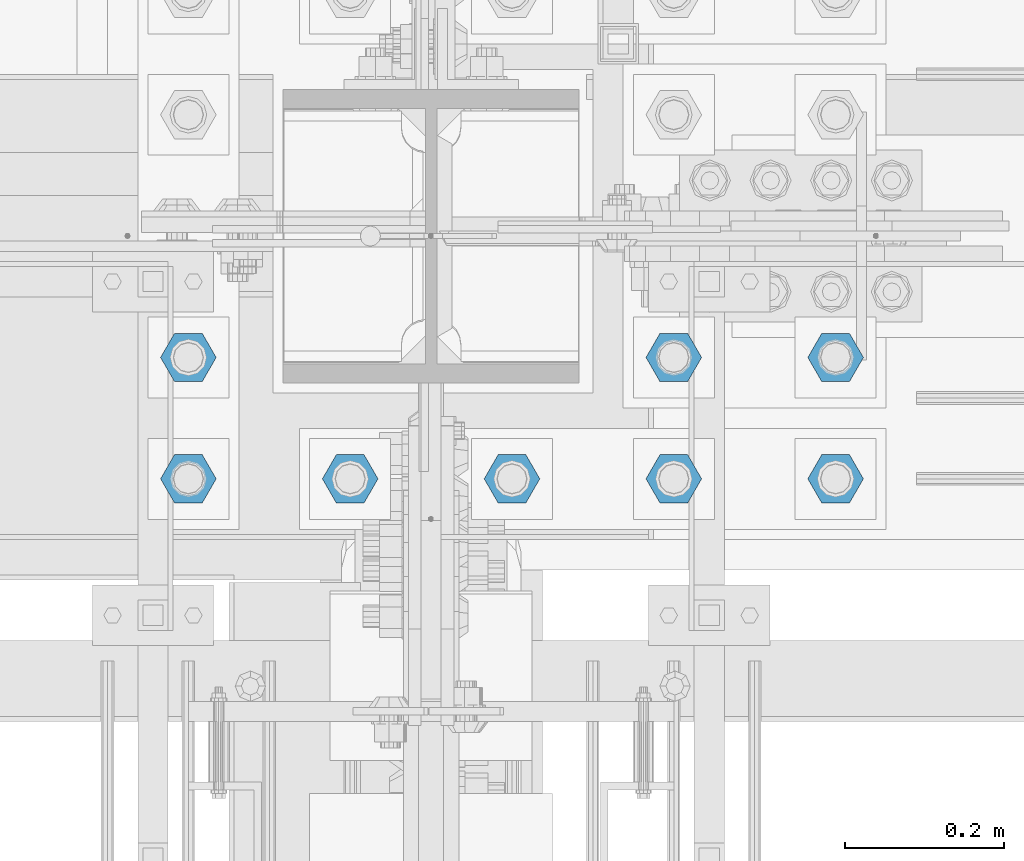
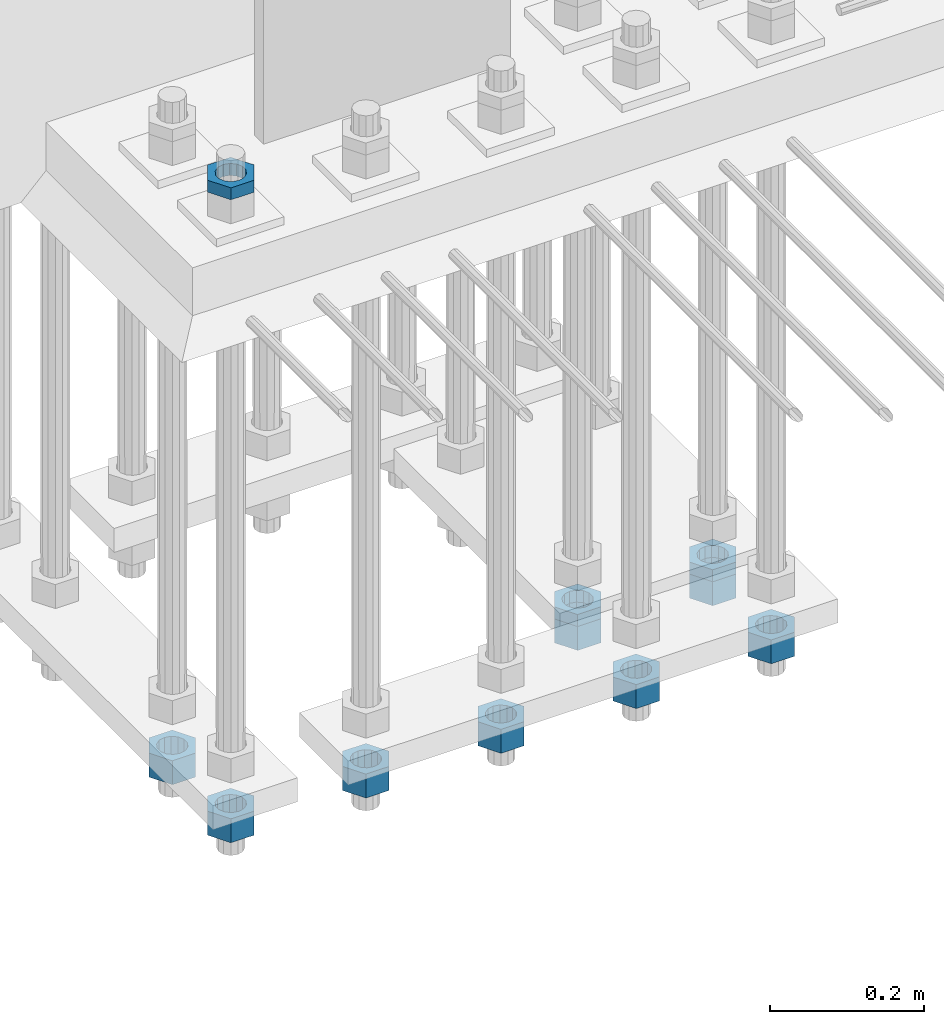
# One storey, part 2824 of 3843: 11 beams, 1 element without a shape of its own.
"""IFC2X3 building model written with IfcOpenShell, lengths in millimetres."""

import ifcopenshell
import ifcopenshell.guid

model = None  # the IFC model being written
_history = None  # IfcOwnerHistory: only IFC2X3 demands one
_inside = {}  # id of a spatial element -> (the spatial element, [elements in it])
_under = {}  # id of a project, library or spatial element -> (it, [spatial elements below it])
_declared = {}  # id of a project -> (the project, [libraries it declares])
_typed = {}  # id of a type object -> (the type object, [elements of that type])
_made_of = {}  # id of a material, layer set ... -> (it, [elements and type objects made of it])


def new_model(schema):
    """Start an empty IFC model of exactly this schema.

    Asked for "IFC4X3", IfcOpenShell would pick the latest addendum, in which some entities
    have other attributes; the version numbers below select the first issue.
    IFC2X3 requires an IfcOwnerHistory on every rooted entity: one is made here for all.
    """
    global model, _history
    if schema == "IFC4X3":
        model = ifcopenshell.file(schema_version=(4, 3, 0, 0))
    else:
        model = ifcopenshell.file(schema=schema)
    _inside.clear()
    _under.clear()
    _declared.clear()
    _typed.clear()
    _made_of.clear()
    _history = None
    if model.schema == "IFC2X3":
        org = make("IfcOrganization", Name="unknown")
        user = make(
            "IfcPersonAndOrganization",
            ThePerson=make("IfcPerson", FamilyName="unknown"),
            TheOrganization=org,
        )
        app = make(
            "IfcApplication",
            ApplicationDeveloper=org,
            Version="unknown",
            ApplicationFullName="unknown",
            ApplicationIdentifier="unknown",
        )
        _history = make(
            "IfcOwnerHistory",
            OwningUser=user,
            OwningApplication=app,
            ChangeAction="ADDED",
            CreationDate=0,
        )
    return model


def make(cls, **values):
    """One entity of the class cls with the attributes given. An attribute that is None is left unset."""
    return model.create_entity(
        cls, **{name: value for name, value in values.items() if value is not None}
    )


def rooted(cls, **values):
    """An entity with a GlobalId (a new one), such as an element, a storey or a relation."""
    return make(cls, GlobalId=ifcopenshell.guid.new(), OwnerHistory=_history, **values)


def si_unit(unit_type, name, prefix=None):
    """IfcSIUnit, for example si_unit("LENGTHUNIT", "METRE", prefix="MILLI")."""
    return make("IfcSIUnit", UnitType=unit_type, Prefix=prefix, Name=name)


def assignment(units):
    """IfcUnitAssignment: the units of a project."""
    return None if units is None else make("IfcUnitAssignment", Units=units)


def point(xyz):
    """IfcCartesianPoint."""
    return None if xyz is None else make("IfcCartesianPoint", Coordinates=xyz)


def direction(xyz):
    """IfcDirection."""
    return None if xyz is None else make("IfcDirection", DirectionRatios=xyz)


def frame(location, z_axis=None, x_axis=None):
    """IfcAxis2Placement3D, a coordinate frame: its origin and axes. An axis left out is left unset."""
    return make(
        "IfcAxis2Placement3D",
        Location=point(location),
        Axis=direction(z_axis),
        RefDirection=direction(x_axis),
    )


def origin_with_axes():
    """The frame at (0, 0, 0) with the z axis (0, 0, 1) and the x axis (1, 0, 0) written out."""
    return frame((0.0, 0.0, 0.0), z_axis=(0.0, 0.0, 1.0), x_axis=(1.0, 0.0, 0.0))


def place(relative_to, where):
    """IfcLocalPlacement: puts the frame where relative to a parent placement (None: the world)."""
    return make(
        "IfcLocalPlacement", PlacementRelTo=relative_to, RelativePlacement=where
    )


def context(
    kind, dimensions, precision=None, world=None, true_north=None, identifier=None
):
    """IfcGeometricRepresentationContext, for example the 3D "Model" context."""
    return make(
        "IfcGeometricRepresentationContext",
        ContextIdentifier=identifier,
        ContextType=kind,
        CoordinateSpaceDimension=dimensions,
        Precision=precision,
        WorldCoordinateSystem=world,
        TrueNorth=true_north,
    )


def subcontext(parent, identifier, kind, view, scale=None):
    """IfcGeometricRepresentationSubContext, for example "Body" below "Model"."""
    return make(
        "IfcGeometricRepresentationSubContext",
        ContextIdentifier=identifier,
        ContextType=kind,
        ParentContext=parent,
        TargetScale=scale,
        TargetView=view,
    )


def project(units=None, contexts=None):
    """IfcProject with its units and contexts."""
    return rooted(
        "IfcProject",
        Name="project",
        RepresentationContexts=contexts,
        UnitsInContext=assignment(units),
    )


def spatial(cls, under=None, at=None, **own):
    """A site, building, storey or space (cls), placed at a placement, below another one or the project."""
    s = rooted(cls, ObjectPlacement=at, **own)
    if under is not None:
        _under.setdefault(under.id(), (under, []))[1].append(s)
    return s


def faces_of(points, faces, orient=None, outer=None):
    """IfcFace entities. A face is a list of loops; a loop is a list of indices into points, from 0.

    orient and outer hold one flag for each loop. By default every Orientation is true, the
    first loop of a face is its IfcFaceOuterBound and the others are IfcFaceBound.
    """
    made = []
    for i, loops in enumerate(faces):
        bounds = []
        for j, loop in enumerate(loops):
            is_outer = j == 0 if outer is None else outer[i][j]
            bounds.append(
                make(
                    "IfcFaceOuterBound" if is_outer else "IfcFaceBound",
                    Bound=make("IfcPolyLoop", Polygon=[points[k] for k in loop]),
                    Orientation=True if orient is None else orient[i][j],
                )
            )
        made.append(make("IfcFace", Bounds=bounds))
    return made


def faceted_brep(points, faces, orient=None, outer=None, voids=None):
    """IfcFacetedBrep: a solid bounded by flat faces; with voids (closed shells), ...WithVoids."""
    shared = [point(p) for p in points]
    hull = make("IfcClosedShell", CfsFaces=faces_of(shared, faces, orient, outer))
    if voids is None:
        return make("IfcFacetedBrep", Outer=hull)
    return make(
        "IfcFacetedBrepWithVoids",
        Outer=hull,
        Voids=[
            make(cls, CfsFaces=faces_of(shared, fs, o, b)) for cls, fs, o, b in voids
        ],
    )


def shape(context_of_items, identifier, shape_type, items):
    """IfcShapeRepresentation: the items that make up one representation, for example the "Body"."""
    return make(
        "IfcShapeRepresentation",
        ContextOfItems=context_of_items,
        RepresentationIdentifier=identifier,
        RepresentationType=shape_type,
        Items=items,
    )


def material(Name=None, Category=None):
    """IfcMaterial."""
    return make("IfcMaterial", Name=Name, Category=Category)


def made_of(thing, what):
    """Note that an element or type object is made of a material, layer set ...; save() writes the relation."""
    if what is not None:
        _made_of.setdefault(what.id(), (what, []))[1].append(thing)
    return thing


def type_object(cls, material=None, **own):
    """A type object (cls), such as IfcWallType, which elements share."""
    return made_of(rooted(cls, **own), material)


def element(
    cls,
    number,
    at=None,
    inside=None,
    cuts=None,
    type_object=None,
    material=None,
    context=None,
    identifier="Body",
    shape_type=None,
    held_by="IfcProductDefinitionShape",
    body=None,
    shapes=None,
    **own,
):
    """One element of the class cls, such as IfcWall. Its Tag is "e" and its number.

    at: its placement. inside: the storey or other place that contains it. cuts: it is an
    opening in that element (IfcRelVoidsElement). A single representation is given by context,
    identifier, shape_type and body (its items); several are given by shapes. held_by: the class
    of the entity that holds the representations. save() writes the other relations.
    """
    e = rooted(cls, Tag="e%d" % number, ObjectPlacement=at, **own)
    if body is not None:
        shapes = [shape(context, identifier, shape_type, body)]
    if shapes is not None:
        e.Representation = make(held_by, Representations=shapes)
    if inside is not None:
        _inside.setdefault(inside.id(), (inside, []))[1].append(e)
    if cuts is not None:
        rooted(
            "IfcRelVoidsElement", RelatingBuildingElement=cuts, RelatedOpeningElement=e
        )
    if type_object is not None:
        _typed.setdefault(type_object.id(), (type_object, []))[1].append(e)
    return made_of(e, material)


def aggregate(whole, parts):
    """IfcRelAggregates: a whole, such as a stair, and the parts it consists of."""
    return rooted("IfcRelAggregates", RelatingObject=whole, RelatedObjects=parts)


def save(model, path):
    """Write the relations noted so far, then the file.

    IfcRelAggregates (storeys below a building ...), IfcRelContainedInSpatialStructure (elements
    in a storey), IfcRelDefinesByType, IfcRelAssociatesMaterial and IfcRelDeclares: one each for
    every whole, place, type object, material and project.
    """
    for whole, parts in _under.values():
        aggregate(whole, parts)
    for where, things in _inside.values():
        rooted(
            "IfcRelContainedInSpatialStructure",
            RelatedElements=things,
            RelatingStructure=where,
        )
    for kind, things in _typed.values():
        rooted("IfcRelDefinesByType", RelatedObjects=things, RelatingType=kind)
    for what, things in _made_of.values():
        rooted("IfcRelAssociatesMaterial", RelatedObjects=things, RelatingMaterial=what)
    for by, libraries in _declared.values():
        rooted("IfcRelDeclares", RelatingContext=by, RelatedDefinitions=libraries)
    model.write(path)


model = new_model("IFC2X3")

# Units and contexts
model_context = context("Model", 3, precision=1e-05, world=origin_with_axes())
body_context = subcontext(model_context, "Body", "Model", "MODEL_VIEW")
ifc_project = project(units=[si_unit("LENGTHUNIT", "METRE", prefix="MILLI"), si_unit("AREAUNIT", "SQUARE_METRE"), si_unit("VOLUMEUNIT", "CUBIC_METRE"), si_unit("MASSUNIT", "GRAM", prefix="KILO"), si_unit("TIMEUNIT", "SECOND"), si_unit("PLANEANGLEUNIT", "RADIAN"), si_unit("SOLIDANGLEUNIT", "STERADIAN"), si_unit("THERMODYNAMICTEMPERATUREUNIT", "DEGREE_CELSIUS"), si_unit("LUMINOUSINTENSITYUNIT", "LUMEN")], contexts=[model_context])

# Site, building, storey
site_placement = place(None, origin_with_axes())
site = spatial("IfcSite", under=ifc_project, at=site_placement, CompositionType="ELEMENT")
building_placement = place(site_placement, origin_with_axes())
building = spatial("IfcBuilding", under=site, at=building_placement, Name="Undefined", CompositionType="ELEMENT")
storey_placement = place(building_placement, origin_with_axes())
storey = spatial("IfcBuildingStorey", under=building, at=storey_placement, Name="Undefined", CompositionType="ELEMENT", Elevation=0.0)

# Assembly, beams
assembly_placement = place(storey_placement, origin_with_axes())
assembly = element("IfcElementAssembly", 1, at=assembly_placement, inside=storey, Name="TEMPLATE", AssemblyPlace="NOTDEFINED", PredefinedType="RIGID_FRAME")
ifc_material = material(Name="STEEL/A572-50")
beam_type_1 = type_object("IfcBeamType", Name="1-1/2_HEAVY_HEX_NUT", PredefinedType="NOTDEFINED")
beam_1_placement = place(assembly_placement, frame((55626.0, 25311.1, 28746.4500015259), z_axis=(0.0, -1.0, 0.0), x_axis=(0.0, 0.0, -1.0)))
beam_1 = element("IfcBeam", 2, at=beam_1_placement, type_object=beam_type_1, material=ifc_material, Name="NUT", ObjectType="1-1/2_HEAVY_HEX_NUT", context=body_context, shape_type="Brep", body=[
    faceted_brep([(0.0, -34.9199981689453, 0.0), (0.0, -17.4599990844727, -30.25), (38.0999999999985, -17.4599990844727, -30.25), (38.0999999999985, -34.9199981689453, 0.0), (0.0, 17.4599990844727, -30.25), (38.0999999999985, 17.4599990844727, -30.25), (0.0, 34.9199981689453, 0.0), (38.0999999999985, 34.9199981689453, 0.0), (0.0, 17.4599990844727, 30.25), (38.0999999999985, 17.4599990844727, 30.25), (0.0, -17.4599990844727, 30.25), (38.0999999999985, -17.4599990844727, 30.25), (0.0, 0.0, 20.6399993896484), (0.0, 8.9553601105581, 18.5959968835959), (38.0999999999985, 8.9553601105581, 18.5959968835959), (38.0999999999985, 0.0, 20.6399993896484), (0.0, 16.1370013209525, 12.8688291298167), (38.0999999999985, 16.1370013209525, 12.8688291298167), (0.0, 20.1225115123816, 4.59283194104501), (38.0999999999985, 20.1225115123816, 4.59283194104501), (0.0, 20.1225115123816, -4.59283194104501), (38.0999999999985, 20.1225115123816, -4.59283194104501), (0.0, 16.1370013209525, -12.8688291298167), (38.0999999999985, 16.1370013209525, -12.8688291298167), (0.0, 8.9553601105581, -18.5959968835959), (38.0999999999985, 8.9553601105581, -18.5959968835959), (0.0, 0.0, -20.6399993896484), (38.0999999999985, 0.0, -20.6399993896484), (0.0, -8.9553601105581, -18.5959968835959), (38.0999999999985, -8.9553601105581, -18.5959968835959), (0.0, -16.1370013209525, -12.8688291298167), (38.0999999999985, -16.1370013209525, -12.8688291298167), (0.0, -20.1225115123816, -4.59283194104501), (38.0999999999985, -20.1225115123816, -4.59283194104501), (0.0, -20.1225115123816, 4.59283194104501), (38.0999999999985, -20.1225115123816, 4.59283194104501), (0.0, -16.1370013209525, 12.8688291298167), (38.0999999999985, -16.1370013209525, 12.8688291298167), (0.0, -8.9553601105581, 18.5959968835959), (38.0999999999985, -8.9553601105581, 18.5959968835959)], [[[0, 1, 2, 3]], [[1, 4, 5, 2]], [[4, 6, 7, 5]], [[6, 8, 9, 7]], [[8, 10, 11, 9]], [[10, 0, 3, 11]], [[12, 13, 14, 15]], [[13, 16, 17, 14]], [[16, 18, 19, 17]], [[18, 20, 21, 19]], [[20, 22, 23, 21]], [[22, 24, 25, 23]], [[24, 26, 27, 25]], [[26, 28, 29, 27]], [[28, 30, 31, 29]], [[30, 32, 33, 31]], [[32, 34, 35, 33]], [[34, 36, 37, 35]], [[36, 38, 39, 37]], [[38, 12, 15, 39]], [[5, 7, 9, 11, 3, 2], [17, 19, 21, 23, 25, 27, 29, 31, 33, 35, 37, 39, 15, 14]], [[10, 8, 6, 4, 1, 0], [38, 36, 34, 32, 30, 28, 26, 24, 22, 20, 18, 16, 13, 12]]]),
])
beam_2_placement = place(assembly_placement, frame((55829.2, 25311.1, 28746.4500015259), z_axis=(0.0, -1.0, 0.0), x_axis=(0.0, 0.0, -1.0)))
beam_2 = element("IfcBeam", 3, at=beam_2_placement, type_object=beam_type_1, material=ifc_material, Name="NUT", ObjectType="1-1/2_HEAVY_HEX_NUT", context=body_context, shape_type="Brep", body=[
    faceted_brep([(0.0, -34.9199981689453, 0.0), (0.0, -17.4599990844727, -30.25), (38.0999999999985, -17.4599990844727, -30.25), (38.0999999999985, -34.9199981689453, 0.0), (0.0, 17.4599990844727, -30.25), (38.0999999999985, 17.4599990844727, -30.25), (0.0, 34.9199981689453, 0.0), (38.0999999999985, 34.9199981689453, 0.0), (0.0, 17.4599990844727, 30.25), (38.0999999999985, 17.4599990844727, 30.25), (0.0, -17.4599990844727, 30.25), (38.0999999999985, -17.4599990844727, 30.25), (0.0, 0.0, 20.6399993896484), (0.0, 8.9553601105581, 18.5959968835959), (38.0999999999985, 8.9553601105581, 18.5959968835959), (38.0999999999985, 0.0, 20.6399993896484), (0.0, 16.1370013209525, 12.8688291298167), (38.0999999999985, 16.1370013209525, 12.8688291298167), (0.0, 20.1225115123816, 4.59283194104501), (38.0999999999985, 20.1225115123816, 4.59283194104501), (0.0, 20.1225115123816, -4.59283194104501), (38.0999999999985, 20.1225115123816, -4.59283194104501), (0.0, 16.1370013209525, -12.8688291298167), (38.0999999999985, 16.1370013209525, -12.8688291298167), (0.0, 8.9553601105581, -18.5959968835959), (38.0999999999985, 8.9553601105581, -18.5959968835959), (0.0, 0.0, -20.6399993896484), (38.0999999999985, 0.0, -20.6399993896484), (0.0, -8.9553601105581, -18.5959968835959), (38.0999999999985, -8.9553601105581, -18.5959968835959), (0.0, -16.1370013209525, -12.8688291298167), (38.0999999999985, -16.1370013209525, -12.8688291298167), (0.0, -20.1225115123816, -4.59283194104501), (38.0999999999985, -20.1225115123816, -4.59283194104501), (0.0, -20.1225115123816, 4.59283194104501), (38.0999999999985, -20.1225115123816, 4.59283194104501), (0.0, -16.1370013209525, 12.8688291298167), (38.0999999999985, -16.1370013209525, 12.8688291298167), (0.0, -8.9553601105581, 18.5959968835959), (38.0999999999985, -8.9553601105581, 18.5959968835959)], [[[0, 1, 2, 3]], [[1, 4, 5, 2]], [[4, 6, 7, 5]], [[6, 8, 9, 7]], [[8, 10, 11, 9]], [[10, 0, 3, 11]], [[12, 13, 14, 15]], [[13, 16, 17, 14]], [[16, 18, 19, 17]], [[18, 20, 21, 19]], [[20, 22, 23, 21]], [[22, 24, 25, 23]], [[24, 26, 27, 25]], [[26, 28, 29, 27]], [[28, 30, 31, 29]], [[30, 32, 33, 31]], [[32, 34, 35, 33]], [[34, 36, 37, 35]], [[36, 38, 39, 37]], [[38, 12, 15, 39]], [[5, 7, 9, 11, 3, 2], [17, 19, 21, 23, 25, 27, 29, 31, 33, 35, 37, 39, 15, 14]], [[10, 8, 6, 4, 1, 0], [38, 36, 34, 32, 30, 28, 26, 24, 22, 20, 18, 16, 13, 12]]]),
])
beam_3_placement = place(assembly_placement, frame((56032.4, 25311.1, 28746.4500015259), z_axis=(0.0, -1.0, 0.0), x_axis=(0.0, 0.0, -1.0)))
beam_3 = element("IfcBeam", 4, at=beam_3_placement, type_object=beam_type_1, material=ifc_material, Name="NUT", ObjectType="1-1/2_HEAVY_HEX_NUT", context=body_context, shape_type="Brep", body=[
    faceted_brep([(0.0, -34.9199981689453, 0.0), (0.0, -17.4599990844727, -30.25), (38.0999999999985, -17.4599990844727, -30.25), (38.0999999999985, -34.9199981689453, 0.0), (0.0, 17.4599990844727, -30.25), (38.0999999999985, 17.4599990844727, -30.25), (0.0, 34.9199981689453, 0.0), (38.0999999999985, 34.9199981689453, 0.0), (0.0, 17.4599990844727, 30.25), (38.0999999999985, 17.4599990844727, 30.25), (0.0, -17.4599990844727, 30.25), (38.0999999999985, -17.4599990844727, 30.25), (0.0, 0.0, 20.6399993896484), (0.0, 8.9553601105581, 18.5959968835959), (38.0999999999985, 8.9553601105581, 18.5959968835959), (38.0999999999985, 0.0, 20.6399993896484), (0.0, 16.1370013209525, 12.8688291298167), (38.0999999999985, 16.1370013209525, 12.8688291298167), (0.0, 20.1225115123816, 4.59283194104501), (38.0999999999985, 20.1225115123816, 4.59283194104501), (0.0, 20.1225115123816, -4.59283194104501), (38.0999999999985, 20.1225115123816, -4.59283194104501), (0.0, 16.1370013209525, -12.8688291298167), (38.0999999999985, 16.1370013209525, -12.8688291298167), (0.0, 8.9553601105581, -18.5959968835959), (38.0999999999985, 8.9553601105581, -18.5959968835959), (0.0, 0.0, -20.6399993896484), (38.0999999999985, 0.0, -20.6399993896484), (0.0, -8.9553601105581, -18.5959968835959), (38.0999999999985, -8.9553601105581, -18.5959968835959), (0.0, -16.1370013209525, -12.8688291298167), (38.0999999999985, -16.1370013209525, -12.8688291298167), (0.0, -20.1225115123816, -4.59283194104501), (38.0999999999985, -20.1225115123816, -4.59283194104501), (0.0, -20.1225115123816, 4.59283194104501), (38.0999999999985, -20.1225115123816, 4.59283194104501), (0.0, -16.1370013209525, 12.8688291298167), (38.0999999999985, -16.1370013209525, 12.8688291298167), (0.0, -8.9553601105581, 18.5959968835959), (38.0999999999985, -8.9553601105581, 18.5959968835959)], [[[0, 1, 2, 3]], [[1, 4, 5, 2]], [[4, 6, 7, 5]], [[6, 8, 9, 7]], [[8, 10, 11, 9]], [[10, 0, 3, 11]], [[12, 13, 14, 15]], [[13, 16, 17, 14]], [[16, 18, 19, 17]], [[18, 20, 21, 19]], [[20, 22, 23, 21]], [[22, 24, 25, 23]], [[24, 26, 27, 25]], [[26, 28, 29, 27]], [[28, 30, 31, 29]], [[30, 32, 33, 31]], [[32, 34, 35, 33]], [[34, 36, 37, 35]], [[36, 38, 39, 37]], [[38, 12, 15, 39]], [[5, 7, 9, 11, 3, 2], [17, 19, 21, 23, 25, 27, 29, 31, 33, 35, 37, 39, 15, 14]], [[10, 8, 6, 4, 1, 0], [38, 36, 34, 32, 30, 28, 26, 24, 22, 20, 18, 16, 13, 12]]]),
])
beam_4_placement = place(assembly_placement, frame((56235.6, 25311.1, 28746.4500015259), z_axis=(0.0, 1.0, 0.0), x_axis=(0.0, 0.0, -1.0)))
beam_4 = element("IfcBeam", 5, at=beam_4_placement, type_object=beam_type_1, material=ifc_material, Name="NUT", ObjectType="1-1/2_HEAVY_HEX_NUT", context=body_context, shape_type="Brep", body=[
    faceted_brep([(0.0, -34.9199981689453, 0.0), (0.0, -17.4599990844727, -30.25), (38.0999999999985, -17.4599990844727, -30.25), (38.0999999999985, -34.9199981689453, 0.0), (0.0, 17.4599990844727, -30.25), (38.0999999999985, 17.4599990844727, -30.25), (0.0, 34.9199981689453, 0.0), (38.0999999999985, 34.9199981689453, 0.0), (0.0, 17.4599990844727, 30.25), (38.0999999999985, 17.4599990844727, 30.25), (0.0, -17.4599990844727, 30.25), (38.0999999999985, -17.4599990844727, 30.25), (0.0, 0.0, 20.6399993896484), (0.0, 8.9553601105581, 18.5959968835959), (38.0999999999985, 8.9553601105581, 18.5959968835959), (38.0999999999985, 0.0, 20.6399993896484), (0.0, 16.1370013209525, 12.8688291298167), (38.0999999999985, 16.1370013209525, 12.8688291298167), (0.0, 20.1225115123816, 4.59283194104501), (38.0999999999985, 20.1225115123816, 4.59283194104501), (0.0, 20.1225115123816, -4.59283194104501), (38.0999999999985, 20.1225115123816, -4.59283194104501), (0.0, 16.1370013209525, -12.8688291298167), (38.0999999999985, 16.1370013209525, -12.8688291298167), (0.0, 8.9553601105581, -18.5959968835959), (38.0999999999985, 8.9553601105581, -18.5959968835959), (0.0, 0.0, -20.6399993896484), (38.0999999999985, 0.0, -20.6399993896484), (0.0, -8.9553601105581, -18.5959968835959), (38.0999999999985, -8.9553601105581, -18.5959968835959), (0.0, -16.1370013209525, -12.8688291298167), (38.0999999999985, -16.1370013209525, -12.8688291298167), (0.0, -20.1225115123816, -4.59283194104501), (38.0999999999985, -20.1225115123816, -4.59283194104501), (0.0, -20.1225115123816, 4.59283194104501), (38.0999999999985, -20.1225115123816, 4.59283194104501), (0.0, -16.1370013209525, 12.8688291298167), (38.0999999999985, -16.1370013209525, 12.8688291298167), (0.0, -8.9553601105581, 18.5959968835959), (38.0999999999985, -8.9553601105581, 18.5959968835959)], [[[0, 1, 2, 3]], [[1, 4, 5, 2]], [[4, 6, 7, 5]], [[6, 8, 9, 7]], [[8, 10, 11, 9]], [[10, 0, 3, 11]], [[12, 13, 14, 15]], [[13, 16, 17, 14]], [[16, 18, 19, 17]], [[18, 20, 21, 19]], [[20, 22, 23, 21]], [[22, 24, 25, 23]], [[24, 26, 27, 25]], [[26, 28, 29, 27]], [[28, 30, 31, 29]], [[30, 32, 33, 31]], [[32, 34, 35, 33]], [[34, 36, 37, 35]], [[36, 38, 39, 37]], [[38, 12, 15, 39]], [[5, 7, 9, 11, 3, 2], [17, 19, 21, 23, 25, 27, 29, 31, 33, 35, 37, 39, 15, 14]], [[10, 8, 6, 4, 1, 0], [38, 36, 34, 32, 30, 28, 26, 24, 22, 20, 18, 16, 13, 12]]]),
])
beam_5_placement = place(assembly_placement, frame((56438.8, 25311.1, 28746.4500015259), z_axis=(0.0, 1.0, 0.0), x_axis=(0.0, 0.0, -1.0)))
beam_5 = element("IfcBeam", 6, at=beam_5_placement, type_object=beam_type_1, material=ifc_material, Name="NUT", ObjectType="1-1/2_HEAVY_HEX_NUT", context=body_context, shape_type="Brep", body=[
    faceted_brep([(0.0, -34.9199981689453, 0.0), (0.0, -17.4599990844727, -30.25), (38.0999999999985, -17.4599990844727, -30.25), (38.0999999999985, -34.9199981689453, 0.0), (0.0, 17.4599990844727, -30.25), (38.0999999999985, 17.4599990844727, -30.25), (0.0, 34.9199981689453, 0.0), (38.0999999999985, 34.9199981689453, 0.0), (0.0, 17.4599990844727, 30.25), (38.0999999999985, 17.4599990844727, 30.25), (0.0, -17.4599990844727, 30.25), (38.0999999999985, -17.4599990844727, 30.25), (0.0, 0.0, 20.6399993896484), (0.0, 8.9553601105581, 18.5959968835959), (38.0999999999985, 8.9553601105581, 18.5959968835959), (38.0999999999985, 0.0, 20.6399993896484), (0.0, 16.1370013209525, 12.8688291298167), (38.0999999999985, 16.1370013209525, 12.8688291298167), (0.0, 20.1225115123816, 4.59283194104501), (38.0999999999985, 20.1225115123816, 4.59283194104501), (0.0, 20.1225115123816, -4.59283194104501), (38.0999999999985, 20.1225115123816, -4.59283194104501), (0.0, 16.1370013209525, -12.8688291298167), (38.0999999999985, 16.1370013209525, -12.8688291298167), (0.0, 8.9553601105581, -18.5959968835959), (38.0999999999985, 8.9553601105581, -18.5959968835959), (0.0, 0.0, -20.6399993896484), (38.0999999999985, 0.0, -20.6399993896484), (0.0, -8.9553601105581, -18.5959968835959), (38.0999999999985, -8.9553601105581, -18.5959968835959), (0.0, -16.1370013209525, -12.8688291298167), (38.0999999999985, -16.1370013209525, -12.8688291298167), (0.0, -20.1225115123816, -4.59283194104501), (38.0999999999985, -20.1225115123816, -4.59283194104501), (0.0, -20.1225115123816, 4.59283194104501), (38.0999999999985, -20.1225115123816, 4.59283194104501), (0.0, -16.1370013209525, 12.8688291298167), (38.0999999999985, -16.1370013209525, 12.8688291298167), (0.0, -8.9553601105581, 18.5959968835959), (38.0999999999985, -8.9553601105581, 18.5959968835959)], [[[0, 1, 2, 3]], [[1, 4, 5, 2]], [[4, 6, 7, 5]], [[6, 8, 9, 7]], [[8, 10, 11, 9]], [[10, 0, 3, 11]], [[12, 13, 14, 15]], [[13, 16, 17, 14]], [[16, 18, 19, 17]], [[18, 20, 21, 19]], [[20, 22, 23, 21]], [[22, 24, 25, 23]], [[24, 26, 27, 25]], [[26, 28, 29, 27]], [[28, 30, 31, 29]], [[30, 32, 33, 31]], [[32, 34, 35, 33]], [[34, 36, 37, 35]], [[36, 38, 39, 37]], [[38, 12, 15, 39]], [[5, 7, 9, 11, 3, 2], [17, 19, 21, 23, 25, 27, 29, 31, 33, 35, 37, 39, 15, 14]], [[10, 8, 6, 4, 1, 0], [38, 36, 34, 32, 30, 28, 26, 24, 22, 20, 18, 16, 13, 12]]]),
])
beam_6_placement = place(assembly_placement, frame((55626.0, 25463.5, 28746.4500015259), z_axis=(0.0, -1.0, 0.0), x_axis=(0.0, 0.0, -1.0)))
beam_6 = element("IfcBeam", 7, at=beam_6_placement, type_object=beam_type_1, material=ifc_material, Name="NUT", ObjectType="1-1/2_HEAVY_HEX_NUT", context=body_context, shape_type="Brep", body=[
    faceted_brep([(0.0, -34.9199981689453, 0.0), (0.0, -17.4599990844727, -30.25), (38.0999999999985, -17.4599990844727, -30.25), (38.0999999999985, -34.9199981689453, 0.0), (0.0, 17.4599990844727, -30.25), (38.0999999999985, 17.4599990844727, -30.25), (0.0, 34.9199981689453, 0.0), (38.0999999999985, 34.9199981689453, 0.0), (0.0, 17.4599990844727, 30.25), (38.0999999999985, 17.4599990844727, 30.25), (0.0, -17.4599990844727, 30.25), (38.0999999999985, -17.4599990844727, 30.25), (0.0, 0.0, 20.6399993896484), (0.0, 8.9553601105581, 18.5959968835959), (38.0999999999985, 8.9553601105581, 18.5959968835959), (38.0999999999985, 0.0, 20.6399993896484), (0.0, 16.1370013209525, 12.8688291298167), (38.0999999999985, 16.1370013209525, 12.8688291298167), (0.0, 20.1225115123816, 4.59283194104501), (38.0999999999985, 20.1225115123816, 4.59283194104501), (0.0, 20.1225115123816, -4.59283194104501), (38.0999999999985, 20.1225115123816, -4.59283194104501), (0.0, 16.1370013209525, -12.8688291298167), (38.0999999999985, 16.1370013209525, -12.8688291298167), (0.0, 8.9553601105581, -18.5959968835959), (38.0999999999985, 8.9553601105581, -18.5959968835959), (0.0, 0.0, -20.6399993896484), (38.0999999999985, 0.0, -20.6399993896484), (0.0, -8.9553601105581, -18.5959968835959), (38.0999999999985, -8.9553601105581, -18.5959968835959), (0.0, -16.1370013209525, -12.8688291298167), (38.0999999999985, -16.1370013209525, -12.8688291298167), (0.0, -20.1225115123816, -4.59283194104501), (38.0999999999985, -20.1225115123816, -4.59283194104501), (0.0, -20.1225115123816, 4.59283194104501), (38.0999999999985, -20.1225115123816, 4.59283194104501), (0.0, -16.1370013209525, 12.8688291298167), (38.0999999999985, -16.1370013209525, 12.8688291298167), (0.0, -8.9553601105581, 18.5959968835959), (38.0999999999985, -8.9553601105581, 18.5959968835959)], [[[0, 1, 2, 3]], [[1, 4, 5, 2]], [[4, 6, 7, 5]], [[6, 8, 9, 7]], [[8, 10, 11, 9]], [[10, 0, 3, 11]], [[12, 13, 14, 15]], [[13, 16, 17, 14]], [[16, 18, 19, 17]], [[18, 20, 21, 19]], [[20, 22, 23, 21]], [[22, 24, 25, 23]], [[24, 26, 27, 25]], [[26, 28, 29, 27]], [[28, 30, 31, 29]], [[30, 32, 33, 31]], [[32, 34, 35, 33]], [[34, 36, 37, 35]], [[36, 38, 39, 37]], [[38, 12, 15, 39]], [[5, 7, 9, 11, 3, 2], [17, 19, 21, 23, 25, 27, 29, 31, 33, 35, 37, 39, 15, 14]], [[10, 8, 6, 4, 1, 0], [38, 36, 34, 32, 30, 28, 26, 24, 22, 20, 18, 16, 13, 12]]]),
])
beam_7_placement = place(assembly_placement, frame((56235.6, 25463.5, 28746.4500015259), z_axis=(0.0, 1.0, 0.0), x_axis=(0.0, 0.0, -1.0)))
beam_7 = element("IfcBeam", 8, at=beam_7_placement, type_object=beam_type_1, material=ifc_material, Name="NUT", ObjectType="1-1/2_HEAVY_HEX_NUT", context=body_context, shape_type="Brep", body=[
    faceted_brep([(0.0, -34.9199981689453, 0.0), (0.0, -17.4599990844727, -30.25), (38.0999999999985, -17.4599990844727, -30.25), (38.0999999999985, -34.9199981689453, 0.0), (0.0, 17.4599990844727, -30.25), (38.0999999999985, 17.4599990844727, -30.25), (0.0, 34.9199981689453, 0.0), (38.0999999999985, 34.9199981689453, 0.0), (0.0, 17.4599990844727, 30.25), (38.0999999999985, 17.4599990844727, 30.25), (0.0, -17.4599990844727, 30.25), (38.0999999999985, -17.4599990844727, 30.25), (0.0, 0.0, 20.6399993896484), (0.0, 8.9553601105581, 18.5959968835959), (38.0999999999985, 8.9553601105581, 18.5959968835959), (38.0999999999985, 0.0, 20.6399993896484), (0.0, 16.1370013209525, 12.8688291298167), (38.0999999999985, 16.1370013209525, 12.8688291298167), (0.0, 20.1225115123816, 4.59283194104501), (38.0999999999985, 20.1225115123816, 4.59283194104501), (0.0, 20.1225115123816, -4.59283194104501), (38.0999999999985, 20.1225115123816, -4.59283194104501), (0.0, 16.1370013209525, -12.8688291298167), (38.0999999999985, 16.1370013209525, -12.8688291298167), (0.0, 8.9553601105581, -18.5959968835959), (38.0999999999985, 8.9553601105581, -18.5959968835959), (0.0, 0.0, -20.6399993896484), (38.0999999999985, 0.0, -20.6399993896484), (0.0, -8.9553601105581, -18.5959968835959), (38.0999999999985, -8.9553601105581, -18.5959968835959), (0.0, -16.1370013209525, -12.8688291298167), (38.0999999999985, -16.1370013209525, -12.8688291298167), (0.0, -20.1225115123816, -4.59283194104501), (38.0999999999985, -20.1225115123816, -4.59283194104501), (0.0, -20.1225115123816, 4.59283194104501), (38.0999999999985, -20.1225115123816, 4.59283194104501), (0.0, -16.1370013209525, 12.8688291298167), (38.0999999999985, -16.1370013209525, 12.8688291298167), (0.0, -8.9553601105581, 18.5959968835959), (38.0999999999985, -8.9553601105581, 18.5959968835959)], [[[0, 1, 2, 3]], [[1, 4, 5, 2]], [[4, 6, 7, 5]], [[6, 8, 9, 7]], [[8, 10, 11, 9]], [[10, 0, 3, 11]], [[12, 13, 14, 15]], [[13, 16, 17, 14]], [[16, 18, 19, 17]], [[18, 20, 21, 19]], [[20, 22, 23, 21]], [[22, 24, 25, 23]], [[24, 26, 27, 25]], [[26, 28, 29, 27]], [[28, 30, 31, 29]], [[30, 32, 33, 31]], [[32, 34, 35, 33]], [[34, 36, 37, 35]], [[36, 38, 39, 37]], [[38, 12, 15, 39]], [[5, 7, 9, 11, 3, 2], [17, 19, 21, 23, 25, 27, 29, 31, 33, 35, 37, 39, 15, 14]], [[10, 8, 6, 4, 1, 0], [38, 36, 34, 32, 30, 28, 26, 24, 22, 20, 18, 16, 13, 12]]]),
])
beam_8_placement = place(assembly_placement, frame((56438.8, 25463.5, 28746.4500015259), z_axis=(0.0, 1.0, 0.0), x_axis=(0.0, 0.0, -1.0)))
beam_8 = element("IfcBeam", 9, at=beam_8_placement, type_object=beam_type_1, material=ifc_material, Name="NUT", ObjectType="1-1/2_HEAVY_HEX_NUT", context=body_context, shape_type="Brep", body=[
    faceted_brep([(0.0, -34.9199981689453, 0.0), (0.0, -17.4599990844727, -30.25), (38.0999999999985, -17.4599990844727, -30.25), (38.0999999999985, -34.9199981689453, 0.0), (0.0, 17.4599990844727, -30.25), (38.0999999999985, 17.4599990844727, -30.25), (0.0, 34.9199981689453, 0.0), (38.0999999999985, 34.9199981689453, 0.0), (0.0, 17.4599990844727, 30.25), (38.0999999999985, 17.4599990844727, 30.25), (0.0, -17.4599990844727, 30.25), (38.0999999999985, -17.4599990844727, 30.25), (0.0, 0.0, 20.6399993896484), (0.0, 8.9553601105581, 18.5959968835959), (38.0999999999985, 8.9553601105581, 18.5959968835959), (38.0999999999985, 0.0, 20.6399993896484), (0.0, 16.1370013209525, 12.8688291298167), (38.0999999999985, 16.1370013209525, 12.8688291298167), (0.0, 20.1225115123816, 4.59283194104501), (38.0999999999985, 20.1225115123816, 4.59283194104501), (0.0, 20.1225115123816, -4.59283194104501), (38.0999999999985, 20.1225115123816, -4.59283194104501), (0.0, 16.1370013209525, -12.8688291298167), (38.0999999999985, 16.1370013209525, -12.8688291298167), (0.0, 8.9553601105581, -18.5959968835959), (38.0999999999985, 8.9553601105581, -18.5959968835959), (0.0, 0.0, -20.6399993896484), (38.0999999999985, 0.0, -20.6399993896484), (0.0, -8.9553601105581, -18.5959968835959), (38.0999999999985, -8.9553601105581, -18.5959968835959), (0.0, -16.1370013209525, -12.8688291298167), (38.0999999999985, -16.1370013209525, -12.8688291298167), (0.0, -20.1225115123816, -4.59283194104501), (38.0999999999985, -20.1225115123816, -4.59283194104501), (0.0, -20.1225115123816, 4.59283194104501), (38.0999999999985, -20.1225115123816, 4.59283194104501), (0.0, -16.1370013209525, 12.8688291298167), (38.0999999999985, -16.1370013209525, 12.8688291298167), (0.0, -8.9553601105581, 18.5959968835959), (38.0999999999985, -8.9553601105581, 18.5959968835959)], [[[0, 1, 2, 3]], [[1, 4, 5, 2]], [[4, 6, 7, 5]], [[6, 8, 9, 7]], [[8, 10, 11, 9]], [[10, 0, 3, 11]], [[12, 13, 14, 15]], [[13, 16, 17, 14]], [[16, 18, 19, 17]], [[18, 20, 21, 19]], [[20, 22, 23, 21]], [[22, 24, 25, 23]], [[24, 26, 27, 25]], [[26, 28, 29, 27]], [[28, 30, 31, 29]], [[30, 32, 33, 31]], [[32, 34, 35, 33]], [[34, 36, 37, 35]], [[36, 38, 39, 37]], [[38, 12, 15, 39]], [[5, 7, 9, 11, 3, 2], [17, 19, 21, 23, 25, 27, 29, 31, 33, 35, 37, 39, 15, 14]], [[10, 8, 6, 4, 1, 0], [38, 36, 34, 32, 30, 28, 26, 24, 22, 20, 18, 16, 13, 12]]]),
])
beam_type_2 = type_object("IfcBeamType", Name="1-1/2_HALF_NUT", PredefinedType="NOTDEFINED")
beam_9_placement = place(assembly_placement, frame((56235.6, 25463.5, 28765.5000015259), z_axis=(0.0, 1.0, 0.0), x_axis=(0.0, 0.0, -1.0)))
beam_9 = element("IfcBeam", 10, at=beam_9_placement, type_object=beam_type_2, material=ifc_material, Name="NUT", ObjectType="1-1/2_HALF_NUT", context=body_context, shape_type="Brep", body=[
    faceted_brep([(0.0, -34.9199981689453, 0.0), (0.0, -17.4599990844727, -30.25), (19.0500000000029, -17.4599990844727, -30.25), (19.0500000000029, -34.9199981689453, 0.0), (0.0, 17.4599990844727, -30.25), (19.0500000000029, 17.4599990844727, -30.25), (0.0, 34.9199981689453, 0.0), (19.0500000000029, 34.9199981689453, 0.0), (0.0, 17.4599990844727, 30.25), (19.0500000000029, 17.4599990844727, 30.25), (0.0, -17.4599990844727, 30.25), (19.0500000000029, -17.4599990844727, 30.25), (0.0, 0.0, 20.6399993896484), (0.0, 8.9553601105581, 18.5959968835959), (19.0500000000029, 8.95536011056538, 18.5959968835959), (19.0500000000029, 0.0, 20.6399993896484), (0.0, 16.1370013209525, 12.8688291298167), (19.0500000000029, 16.1370013209489, 12.8688291298167), (0.0, 20.1225115123816, 4.59283194104501), (19.0500000000029, 20.1225115123852, 4.59283194104501), (0.0, 20.1225115123816, -4.59283194104501), (19.0500000000029, 20.1225115123852, -4.59283194104501), (0.0, 16.1370013209525, -12.8688291298167), (19.0500000000029, 16.1370013209489, -12.8688291298167), (0.0, 8.9553601105581, -18.5959968835959), (19.0500000000029, 8.95536011056538, -18.5959968835959), (0.0, 0.0, -20.6399993896484), (19.0500000000029, 0.0, -20.6399993896484), (0.0, -8.9553601105581, -18.5959968835959), (19.0500000000029, -8.95536011056538, -18.5959968835959), (0.0, -16.1370013209525, -12.8688291298167), (19.0500000000029, -16.1370013209489, -12.8688291298167), (0.0, -20.1225115123816, -4.59283194104501), (19.0500000000029, -20.1225115123852, -4.59283194104501), (0.0, -20.1225115123816, 4.59283194104501), (19.0500000000029, -20.1225115123852, 4.59283194104501), (0.0, -16.1370013209525, 12.8688291298167), (19.0500000000029, -16.1370013209489, 12.8688291298167), (0.0, -8.9553601105581, 18.5959968835959), (19.0500000000029, -8.95536011056538, 18.5959968835959)], [[[0, 1, 2, 3]], [[1, 4, 5, 2]], [[4, 6, 7, 5]], [[6, 8, 9, 7]], [[8, 10, 11, 9]], [[10, 0, 3, 11]], [[12, 13, 14, 15]], [[13, 16, 17, 14]], [[16, 18, 19, 17]], [[18, 20, 21, 19]], [[20, 22, 23, 21]], [[22, 24, 25, 23]], [[24, 26, 27, 25]], [[26, 28, 29, 27]], [[28, 30, 31, 29]], [[30, 32, 33, 31]], [[32, 34, 35, 33]], [[34, 36, 37, 35]], [[36, 38, 39, 37]], [[38, 12, 15, 39]], [[5, 7, 9, 11, 3, 2], [17, 19, 21, 23, 25, 27, 29, 31, 33, 35, 37, 39, 15, 14]], [[10, 8, 6, 4, 1, 0], [38, 36, 34, 32, 30, 28, 26, 24, 22, 20, 18, 16, 13, 12]]]),
])
beam_10_placement = place(assembly_placement, frame((56438.8, 25463.5, 28765.5000015259), z_axis=(0.0, 1.0, 0.0), x_axis=(0.0, 0.0, -1.0)))
beam_10 = element("IfcBeam", 11, at=beam_10_placement, type_object=beam_type_2, material=ifc_material, Name="NUT", ObjectType="1-1/2_HALF_NUT", context=body_context, shape_type="Brep", body=[
    faceted_brep([(0.0, -34.9199981689453, 0.0), (0.0, -17.4599990844727, -30.25), (19.0500000000029, -17.4599990844727, -30.25), (19.0500000000029, -34.9199981689453, 0.0), (0.0, 17.4599990844727, -30.25), (19.0500000000029, 17.4599990844727, -30.25), (0.0, 34.9199981689453, 0.0), (19.0500000000029, 34.9199981689453, 0.0), (0.0, 17.4599990844727, 30.25), (19.0500000000029, 17.4599990844727, 30.25), (0.0, -17.4599990844727, 30.25), (19.0500000000029, -17.4599990844727, 30.25), (0.0, 0.0, 20.6399993896484), (0.0, 8.9553601105581, 18.5959968835959), (19.0500000000029, 8.95536011056538, 18.5959968835959), (19.0500000000029, 0.0, 20.6399993896484), (0.0, 16.1370013209525, 12.8688291298167), (19.0500000000029, 16.1370013209489, 12.8688291298167), (0.0, 20.1225115123816, 4.59283194104501), (19.0500000000029, 20.1225115123852, 4.59283194104501), (0.0, 20.1225115123816, -4.59283194104501), (19.0500000000029, 20.1225115123852, -4.59283194104501), (0.0, 16.1370013209525, -12.8688291298167), (19.0500000000029, 16.1370013209489, -12.8688291298167), (0.0, 8.9553601105581, -18.5959968835959), (19.0500000000029, 8.95536011056538, -18.5959968835959), (0.0, 0.0, -20.6399993896484), (19.0500000000029, 0.0, -20.6399993896484), (0.0, -8.9553601105581, -18.5959968835959), (19.0500000000029, -8.95536011056538, -18.5959968835959), (0.0, -16.1370013209525, -12.8688291298167), (19.0500000000029, -16.1370013209489, -12.8688291298167), (0.0, -20.1225115123816, -4.59283194104501), (19.0500000000029, -20.1225115123852, -4.59283194104501), (0.0, -20.1225115123816, 4.59283194104501), (19.0500000000029, -20.1225115123852, 4.59283194104501), (0.0, -16.1370013209525, 12.8688291298167), (19.0500000000029, -16.1370013209489, 12.8688291298167), (0.0, -8.9553601105581, 18.5959968835959), (19.0500000000029, -8.95536011056538, 18.5959968835959)], [[[0, 1, 2, 3]], [[1, 4, 5, 2]], [[4, 6, 7, 5]], [[6, 8, 9, 7]], [[8, 10, 11, 9]], [[10, 0, 3, 11]], [[12, 13, 14, 15]], [[13, 16, 17, 14]], [[16, 18, 19, 17]], [[18, 20, 21, 19]], [[20, 22, 23, 21]], [[22, 24, 25, 23]], [[24, 26, 27, 25]], [[26, 28, 29, 27]], [[28, 30, 31, 29]], [[30, 32, 33, 31]], [[32, 34, 35, 33]], [[34, 36, 37, 35]], [[36, 38, 39, 37]], [[38, 12, 15, 39]], [[5, 7, 9, 11, 3, 2], [17, 19, 21, 23, 25, 27, 29, 31, 33, 35, 37, 39, 15, 14]], [[10, 8, 6, 4, 1, 0], [38, 36, 34, 32, 30, 28, 26, 24, 22, 20, 18, 16, 13, 12]]]),
])
beam_11_placement = place(assembly_placement, frame((55626.0, 25311.1, 29749.75), z_axis=(0.0, -1.0, 0.0), x_axis=(0.0, 0.0, -1.0)))
beam_11 = element("IfcBeam", 12, at=beam_11_placement, type_object=beam_type_2, material=ifc_material, Name="NUT", ObjectType="1-1/2_HALF_NUT", context=body_context, shape_type="Brep", body=[
    faceted_brep([(0.0, -34.9199981689453, 0.0), (0.0, -17.4599990844727, -30.25), (19.0500000000029, -17.4599990844727, -30.25), (19.0500000000029, -34.9199981689453, 0.0), (0.0, 17.4599990844727, -30.25), (19.0500000000029, 17.4599990844727, -30.25), (0.0, 34.9199981689453, 0.0), (19.0500000000029, 34.9199981689453, 0.0), (0.0, 17.4599990844727, 30.25), (19.0500000000029, 17.4599990844727, 30.25), (0.0, -17.4599990844727, 30.25), (19.0500000000029, -17.4599990844727, 30.25), (0.0, 0.0, 20.6399993896484), (0.0, 8.9553601105581, 18.5959968835959), (19.0500000000029, 8.95536011056538, 18.5959968835959), (19.0500000000029, 0.0, 20.6399993896484), (0.0, 16.1370013209525, 12.8688291298167), (19.0500000000029, 16.1370013209489, 12.8688291298167), (0.0, 20.1225115123816, 4.59283194104501), (19.0500000000029, 20.1225115123852, 4.59283194104501), (0.0, 20.1225115123816, -4.59283194104501), (19.0500000000029, 20.1225115123852, -4.59283194104501), (0.0, 16.1370013209525, -12.8688291298167), (19.0500000000029, 16.1370013209489, -12.8688291298167), (0.0, 8.9553601105581, -18.5959968835959), (19.0500000000029, 8.95536011056538, -18.5959968835959), (0.0, 0.0, -20.6399993896484), (19.0500000000029, 0.0, -20.6399993896484), (0.0, -8.9553601105581, -18.5959968835959), (19.0500000000029, -8.95536011056538, -18.5959968835959), (0.0, -16.1370013209525, -12.8688291298167), (19.0500000000029, -16.1370013209489, -12.8688291298167), (0.0, -20.1225115123816, -4.59283194104501), (19.0500000000029, -20.1225115123852, -4.59283194104501), (0.0, -20.1225115123816, 4.59283194104501), (19.0500000000029, -20.1225115123852, 4.59283194104501), (0.0, -16.1370013209525, 12.8688291298167), (19.0500000000029, -16.1370013209489, 12.8688291298167), (0.0, -8.9553601105581, 18.5959968835959), (19.0500000000029, -8.95536011056538, 18.5959968835959)], [[[0, 1, 2, 3]], [[1, 4, 5, 2]], [[4, 6, 7, 5]], [[6, 8, 9, 7]], [[8, 10, 11, 9]], [[10, 0, 3, 11]], [[12, 13, 14, 15]], [[13, 16, 17, 14]], [[16, 18, 19, 17]], [[18, 20, 21, 19]], [[20, 22, 23, 21]], [[22, 24, 25, 23]], [[24, 26, 27, 25]], [[26, 28, 29, 27]], [[28, 30, 31, 29]], [[30, 32, 33, 31]], [[32, 34, 35, 33]], [[34, 36, 37, 35]], [[36, 38, 39, 37]], [[38, 12, 15, 39]], [[5, 7, 9, 11, 3, 2], [17, 19, 21, 23, 25, 27, 29, 31, 33, 35, 37, 39, 15, 14]], [[10, 8, 6, 4, 1, 0], [38, 36, 34, 32, 30, 28, 26, 24, 22, 20, 18, 16, 13, 12]]]),
])
aggregate(assembly, [beam_9, beam_10, beam_1, beam_2, beam_3, beam_4, beam_5, beam_6, beam_7, beam_8, beam_11])

save(model, "model.ifc")
